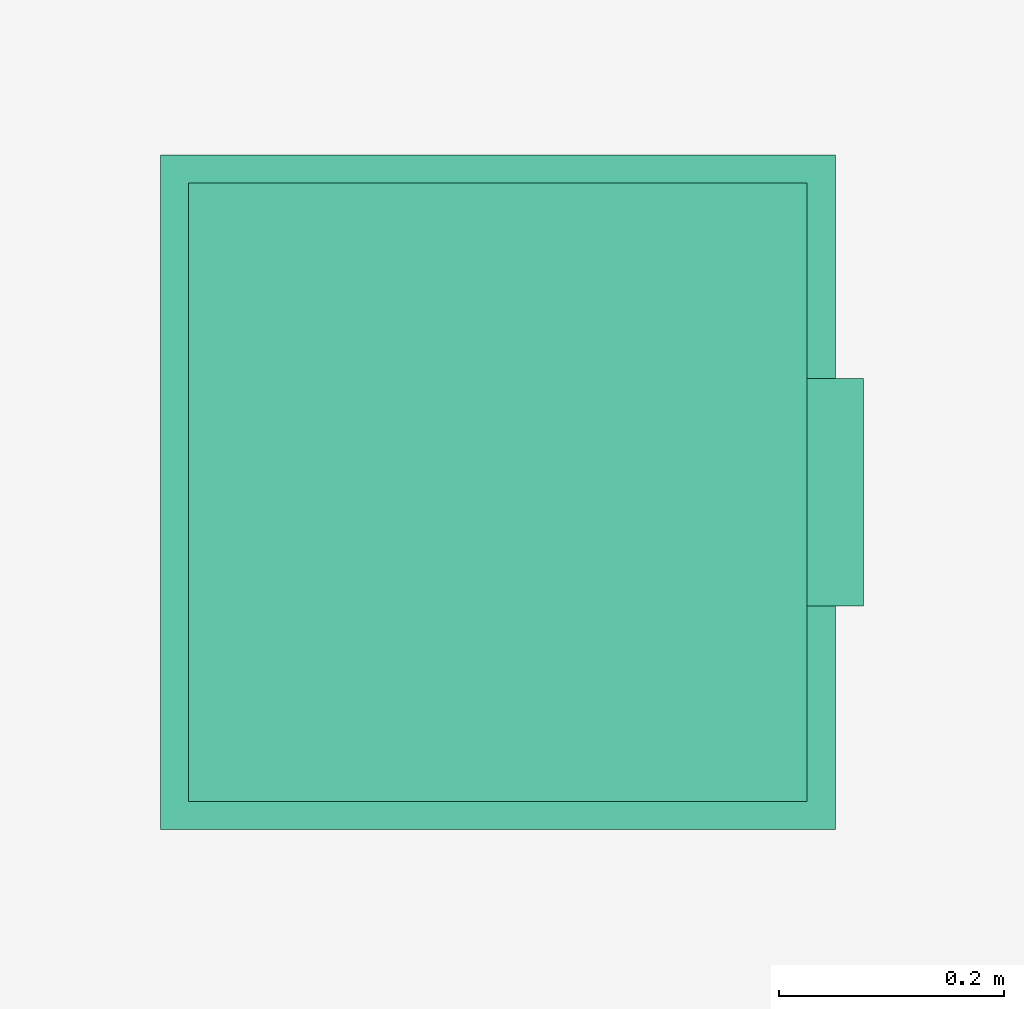
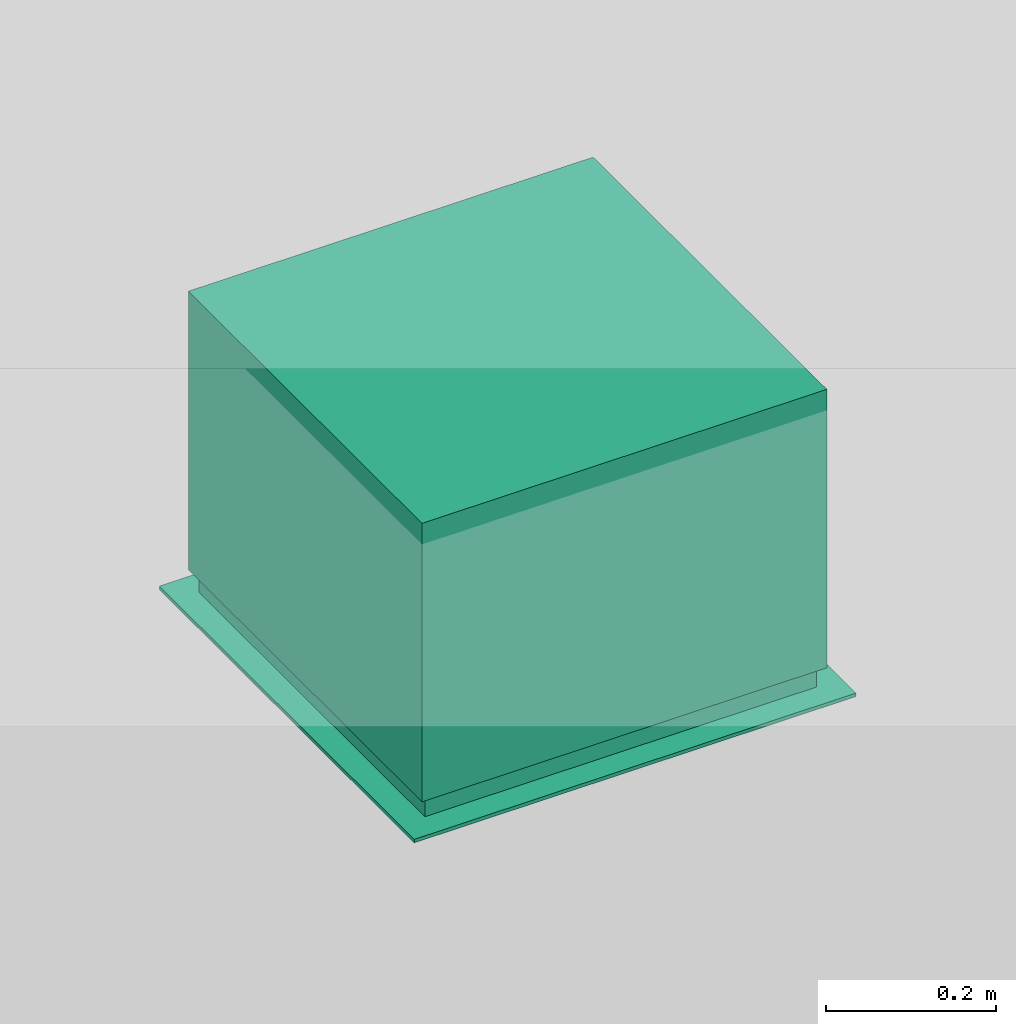
# One storey, part 2 of 2: 1 air terminal.
"""IFC4 building model written with IfcOpenShell, lengths in metres."""

from ifc_helpers import new_model, entity, si_unit, converted_unit, derived_unit, direction, frame, origin_with_axes, place, context, subcontext, project, spatial, open_shell, faceted_brep, surface_model, type_object, element, save


model = new_model("IFC4")

# Units and contexts
model_context = context("Model", 3, precision=1e-05, world=origin_with_axes(), true_north=direction((0.0, 1.0)))
plan_context = context("Plan", 3, precision=1e-05, world=origin_with_axes(), true_north=direction((0.0, 1.0)))
body_context = subcontext(model_context, "Body", "Model", "MODEL_VIEW")
ifc_project = project(units=[si_unit("LENGTHUNIT", "METRE"), si_unit("AREAUNIT", "SQUARE_METRE"), si_unit("VOLUMEUNIT", "CUBIC_METRE"), converted_unit("PLANEANGLEUNIT", "DEGREE", entity("IfcPlaneAngleMeasure", 0.0174532925199), si_unit("PLANEANGLEUNIT", "RADIAN"), dimensions=[0, 0, 0, 0, 0, 0, 0]), si_unit("SOLIDANGLEUNIT", "STERADIAN"), converted_unit("TIMEUNIT", "Year", entity("IfcTimeMeasure", 31556926.0), si_unit("TIMEUNIT", "SECOND"), dimensions=[0, 0, 1, 0, 0, 0, 0]), si_unit("MASSUNIT", "GRAM", prefix="KILO"), si_unit("THERMODYNAMICTEMPERATUREUNIT", "DEGREE_CELSIUS"), si_unit("LUMINOUSINTENSITYUNIT", "LUMEN"), si_unit("ENERGYUNIT", "JOULE", prefix="MEGA"), derived_unit("THERMALCONDUCTANCEUNIT", [(si_unit("POWERUNIT", "WATT"), 1), (si_unit("LENGTHUNIT", "METRE"), -1), (si_unit("THERMODYNAMICTEMPERATUREUNIT", "KELVIN"), -1)]), derived_unit("SPECIFICHEATCAPACITYUNIT", [(si_unit("ENERGYUNIT", "JOULE"), 1), (si_unit("MASSUNIT", "GRAM", prefix="KILO"), -1), (si_unit("THERMODYNAMICTEMPERATUREUNIT", "KELVIN"), -1)]), derived_unit("MASSDENSITYUNIT", [(si_unit("MASSUNIT", "GRAM", prefix="KILO"), 1), (si_unit("VOLUMEUNIT", "CUBIC_METRE"), -1)])], contexts=[model_context, plan_context])

# Site, building, storey, space
site_placement = place(None, origin_with_axes())
site = spatial("IfcSite", under=ifc_project, at=site_placement, CompositionType="ELEMENT")
building_placement = place(site_placement, origin_with_axes())
building = spatial("IfcBuilding", under=site, at=building_placement, Name="Test-Building", CompositionType="ELEMENT")
storey_placement = place(building_placement, origin_with_axes())
storey = spatial("IfcBuildingStorey", under=building, at=storey_placement, Name="EG", CompositionType="ELEMENT", Elevation=0.0)
space_placement = place(storey_placement, frame((0.4, 5.33, 0.0), z_axis=(0.0, 0.0, 1.0), x_axis=(0.0, -1.0, 0.0)))
space = spatial("IfcSpace", under=storey, at=space_placement, CompositionType="ELEMENT")

# Air terminal
air_terminal_type = type_object("IfcAirTerminalType", Name="22", PredefinedType="DIFFUSER")
air_terminal_placement = place(space_placement, frame((1.30756306791, 5.44595197786, 2.6), z_axis=(0.0, 0.0, 1.0), x_axis=(0.0, 1.0, 0.0)))
element("IfcAirTerminal", 1, at=air_terminal_placement, inside=space, type_object=air_terminal_type, Name="Air Terminal", context=body_context, shape_type="SurfaceModel", body=[
    faceted_brep([(-0.3, -0.3, -0.005), (0.3, -0.3, -0.005), (0.3, -0.3, 0.0), (-0.3, -0.3, 0.0), (-0.3, 0.3, -0.005), (0.3, 0.3, -0.005), (0.25, 0.0, -0.005), (0.246201938253, 0.0434120444167, -0.005), (0.234923155196, 0.0855050358314, -0.005), (0.216506350946, 0.125, -0.005), (0.19151111078, 0.160696902422, -0.005), (0.160696902422, 0.19151111078, -0.005), (0.125, 0.216506350946, -0.005), (0.0855050358314, 0.234923155196, -0.005), (0.0434120444167, 0.246201938253, -0.005), (0.0, 0.25, -0.005), (-0.0434120444167, 0.246201938253, -0.005), (-0.0855050358314, 0.234923155196, -0.005), (-0.125, 0.216506350946, -0.005), (-0.160696902422, 0.19151111078, -0.005), (-0.19151111078, 0.160696902422, -0.005), (-0.216506350946, 0.125, -0.005), (-0.234923155196, 0.0855050358314, -0.005), (-0.246201938253, 0.0434120444167, -0.005), (-0.25, 0.0, -0.005), (-0.246201938253, -0.0434120444167, -0.005), (-0.234923155196, -0.0855050358314, -0.005), (-0.216506350946, -0.125, -0.005), (-0.19151111078, -0.160696902422, -0.005), (-0.160696902422, -0.19151111078, -0.005), (-0.125, -0.216506350946, -0.005), (-0.0855050358314, -0.234923155196, -0.005), (-0.0434120444167, -0.246201938253, -0.005), (0.0, -0.25, -0.005), (0.0434120444167, -0.246201938253, -0.005), (0.0855050358314, -0.234923155196, -0.005), (0.125, -0.216506350946, -0.005), (0.160696902422, -0.19151111078, -0.005), (0.19151111078, -0.160696902422, -0.005), (0.216506350946, -0.125, -0.005), (0.234923155196, -0.0855050358314, -0.005), (0.246201938253, -0.0434120444167, -0.005), (0.3, 0.3, 0.0), (-0.3, 0.3, 0.0), (0.25, 0.0, 0.0), (0.246201938253, -0.0434120444167, 0.0), (0.234923155196, -0.0855050358314, 0.0), (0.216506350946, -0.125, 0.0), (0.19151111078, -0.160696902422, 0.0), (0.160696902422, -0.19151111078, 0.0), (0.125, -0.216506350946, 0.0), (0.0855050358314, -0.234923155196, 0.0), (0.0434120444167, -0.246201938253, 0.0), (0.0, -0.25, 0.0), (-0.0434120444167, -0.246201938253, 0.0), (-0.0855050358314, -0.234923155196, 0.0), (-0.125, -0.216506350946, 0.0), (-0.160696902422, -0.19151111078, 0.0), (-0.19151111078, -0.160696902422, 0.0), (-0.216506350946, -0.125, 0.0), (-0.234923155196, -0.0855050358314, 0.0), (-0.246201938253, -0.0434120444167, 0.0), (-0.25, 0.0, 0.0), (-0.246201938253, 0.0434120444167, 0.0), (-0.234923155196, 0.0855050358314, 0.0), (-0.216506350946, 0.125, 0.0), (-0.19151111078, 0.160696902422, 0.0), (-0.160696902422, 0.19151111078, 0.0), (-0.125, 0.216506350946, 0.0), (-0.0855050358314, 0.234923155196, 0.0), (-0.0434120444167, 0.246201938253, 0.0), (0.0, 0.25, 0.0), (0.0434120444167, 0.246201938253, 0.0), (0.0855050358314, 0.234923155196, 0.0), (0.125, 0.216506350946, 0.0), (0.160696902422, 0.19151111078, 0.0), (0.19151111078, 0.160696902422, 0.0), (0.216506350946, 0.125, 0.0), (0.234923155196, 0.0855050358314, 0.0), (0.246201938253, 0.0434120444167, 0.0)], [[[0, 1, 2, 3]], [[0, 4, 5, 1], [6, 7, 8, 9, 10, 11, 12, 13, 14, 15, 16, 17, 18, 19, 20, 21, 22, 23, 24, 25, 26, 27, 28, 29, 30, 31, 32, 33, 34, 35, 36, 37, 38, 39, 40, 41]], [[1, 5, 42, 2]], [[3, 2, 42, 43], [44, 45, 46, 47, 48, 49, 50, 51, 52, 53, 54, 55, 56, 57, 58, 59, 60, 61, 62, 63, 64, 65, 66, 67, 68, 69, 70, 71, 72, 73, 74, 75, 76, 77, 78, 79]], [[4, 0, 3, 43]], [[5, 4, 43, 42]], [[7, 6, 44, 79]], [[8, 7, 79, 78]], [[9, 8, 78, 77]], [[10, 9, 77, 76]], [[11, 10, 76, 75]], [[12, 11, 75, 74]], [[13, 12, 74, 73]], [[14, 13, 73, 72]], [[15, 14, 72, 71]], [[16, 15, 71, 70]], [[17, 16, 70, 69]], [[18, 17, 69, 68]], [[19, 18, 68, 67]], [[20, 19, 67, 66]], [[21, 20, 66, 65]], [[22, 21, 65, 64]], [[23, 22, 64, 63]], [[24, 23, 63, 62]], [[25, 24, 62, 61]], [[26, 25, 61, 60]], [[27, 26, 60, 59]], [[28, 27, 59, 58]], [[29, 28, 58, 57]], [[30, 29, 57, 56]], [[31, 30, 56, 55]], [[32, 31, 55, 54]], [[33, 32, 54, 53]], [[34, 33, 53, 52]], [[35, 34, 52, 51]], [[36, 35, 51, 50]], [[37, 36, 50, 49]], [[38, 37, 49, 48]], [[39, 38, 48, 47]], [[40, 39, 47, 46]], [[41, 40, 46, 45]], [[6, 41, 45, 44]]]),
    surface_model("IfcShellBasedSurfaceModel", [(-0.0434120444167, 0.246201938253, 0.04), (0.0, 0.25, 0.04), (0.0, 0.25, 0.0), (-0.0434120444167, 0.246201938253, 0.0), (0.0434120444167, 0.246201938253, 0.04), (0.0434120444167, 0.246201938253, 0.0), (-0.0855050358314, 0.234923155196, 0.04), (-0.0855050358314, 0.234923155196, 0.0), (0.0855050358314, 0.234923155196, 0.04), (0.0855050358314, 0.234923155196, 0.0), (-0.125, 0.216506350946, 0.04), (-0.125, 0.216506350946, 0.0), (0.125, 0.216506350946, 0.04), (0.125, 0.216506350946, 0.0), (-0.160696902422, 0.19151111078, 0.04), (-0.160696902422, 0.19151111078, 0.0), (0.160696902422, 0.19151111078, 0.04), (0.160696902422, 0.19151111078, 0.0), (-0.19151111078, 0.160696902422, 0.04), (-0.19151111078, 0.160696902422, 0.0), (0.19151111078, 0.160696902422, 0.04), (0.19151111078, 0.160696902422, 0.0), (-0.216506350946, 0.125, 0.04), (-0.216506350946, 0.125, 0.0), (0.216506350946, 0.125, 0.04), (0.216506350946, 0.125, 0.0), (-0.234923155196, 0.0855050358314, 0.04), (-0.234923155196, 0.0855050358314, 0.0), (0.234923155196, 0.0855050358314, 0.04), (0.234923155196, 0.0855050358314, 0.0), (-0.246201938253, 0.0434120444167, 0.04), (-0.246201938253, 0.0434120444167, 0.0), (0.246201938253, 0.0434120444167, 0.04), (0.246201938253, 0.0434120444167, 0.0), (-0.25, 0.0, 0.04), (-0.25, 0.0, 0.0), (0.25, 0.0, 0.04), (0.25, 0.0, 0.0), (-0.246201938253, -0.0434120444167, 0.04), (-0.246201938253, -0.0434120444167, 0.0), (0.246201938253, -0.0434120444167, 0.04), (0.246201938253, -0.0434120444167, 0.0), (-0.234923155196, -0.0855050358314, 0.04), (-0.234923155196, -0.0855050358314, 0.0), (0.234923155196, -0.0855050358314, 0.04), (0.234923155196, -0.0855050358314, 0.0), (-0.216506350946, -0.125, 0.04), (-0.216506350946, -0.125, 0.0), (0.216506350946, -0.125, 0.04), (0.216506350946, -0.125, 0.0), (-0.19151111078, -0.160696902422, 0.04), (-0.19151111078, -0.160696902422, 0.0), (0.19151111078, -0.160696902422, 0.04), (0.19151111078, -0.160696902422, 0.0), (-0.160696902422, -0.19151111078, 0.04), (-0.160696902422, -0.19151111078, 0.0), (0.160696902422, -0.19151111078, 0.04), (0.160696902422, -0.19151111078, 0.0), (-0.125, -0.216506350946, 0.04), (-0.125, -0.216506350946, 0.0), (0.125, -0.216506350946, 0.04), (0.125, -0.216506350946, 0.0), (-0.0855050358314, -0.234923155196, 0.04), (-0.0855050358314, -0.234923155196, 0.0), (0.0855050358314, -0.234923155196, 0.04), (0.0855050358314, -0.234923155196, 0.0), (-0.0434120444167, -0.246201938253, 0.04), (-0.0434120444167, -0.246201938253, 0.0), (0.0434120444167, -0.246201938253, 0.04), (0.0434120444167, -0.246201938253, 0.0), (0.0, -0.25, 0.04), (0.0, -0.25, 0.0)], [open_shell([[[0, 1, 2, 3]], [[1, 4, 5, 2]], [[6, 0, 3, 7]], [[4, 8, 9, 5]], [[10, 6, 7, 11]], [[8, 12, 13, 9]], [[14, 10, 11, 15]], [[12, 16, 17, 13]], [[18, 14, 15, 19]], [[16, 20, 21, 17]], [[22, 18, 19, 23]], [[20, 24, 25, 21]], [[26, 22, 23, 27]], [[24, 28, 29, 25]], [[30, 26, 27, 31]], [[28, 32, 33, 29]], [[34, 30, 31, 35]], [[32, 36, 37, 33]], [[38, 34, 35, 39]], [[36, 40, 41, 37]], [[42, 38, 39, 43]], [[40, 44, 45, 41]], [[46, 42, 43, 47]], [[44, 48, 49, 45]], [[50, 46, 47, 51]], [[48, 52, 53, 49]], [[54, 50, 51, 55]], [[52, 56, 57, 53]], [[58, 54, 55, 59]], [[56, 60, 61, 57]], [[62, 58, 59, 63]], [[60, 64, 65, 61]], [[66, 62, 63, 67]], [[64, 68, 69, 65]], [[70, 66, 67, 71]], [[68, 70, 71, 69]]])]),
    faceted_brep([(0.0833333333333, 0.0, 0.0), (0.082067312751, 0.0144706814722, 0.0), (0.082067312751, 0.0144706814722, 0.04), (0.0833333333333, 0.0, 0.04), (0.082067312751, -0.0144706814722, 0.0), (0.0783077183988, -0.0285016786105, 0.0), (0.0721687836487, -0.0416666666667, 0.0), (0.0638370369266, -0.0535656341405, 0.0), (0.0535656341405, -0.0638370369266, 0.0), (0.0416666666667, -0.0721687836487, 0.0), (0.0285016786105, -0.0783077183988, 0.0), (0.0144706814722, -0.082067312751, 0.0), (0.0, -0.0833333333333, 0.0), (-0.0144706814722, -0.082067312751, 0.0), (-0.0285016786105, -0.0783077183988, 0.0), (-0.0416666666667, -0.0721687836487, 0.0), (-0.0535656341405, -0.0638370369266, 0.0), (-0.0638370369266, -0.0535656341405, 0.0), (-0.0721687836487, -0.0416666666667, 0.0), (-0.0783077183988, -0.0285016786105, 0.0), (-0.082067312751, -0.0144706814722, 0.0), (-0.0833333333333, 0.0, 0.0), (-0.082067312751, 0.0144706814722, 0.0), (-0.0783077183988, 0.0285016786105, 0.0), (-0.0721687836487, 0.0416666666667, 0.0), (-0.0638370369266, 0.0535656341405, 0.0), (-0.0535656341405, 0.0638370369266, 0.0), (-0.0416666666667, 0.0721687836487, 0.0), (-0.0285016786105, 0.0783077183988, 0.0), (-0.0144706814722, 0.082067312751, 0.0), (0.0, 0.0833333333333, 0.0), (0.0144706814722, 0.082067312751, 0.0), (0.0285016786105, 0.0783077183988, 0.0), (0.0416666666667, 0.0721687836487, 0.0), (0.0535656341405, 0.0638370369266, 0.0), (0.0638370369266, 0.0535656341405, 0.0), (0.0721687836487, 0.0416666666667, 0.0), (0.0783077183988, 0.0285016786105, 0.0), (0.0783077183988, 0.0285016786105, 0.04), (0.0721687836487, 0.0416666666667, 0.04), (0.0638370369266, 0.0535656341405, 0.04), (0.0535656341405, 0.0638370369266, 0.04), (0.0416666666667, 0.0721687836487, 0.04), (0.0285016786105, 0.0783077183988, 0.04), (0.0144706814722, 0.082067312751, 0.04), (0.0, 0.0833333333333, 0.04), (-0.0144706814722, 0.082067312751, 0.04), (-0.0285016786105, 0.0783077183988, 0.04), (-0.0416666666667, 0.0721687836487, 0.04), (-0.0535656341405, 0.0638370369266, 0.04), (-0.0638370369266, 0.0535656341405, 0.04), (-0.0721687836487, 0.0416666666667, 0.04), (-0.0783077183988, 0.0285016786105, 0.04), (-0.082067312751, 0.0144706814722, 0.04), (-0.0833333333333, 0.0, 0.04), (-0.082067312751, -0.0144706814722, 0.04), (-0.0783077183988, -0.0285016786105, 0.04), (-0.0721687836487, -0.0416666666667, 0.04), (-0.0638370369266, -0.0535656341405, 0.04), (-0.0535656341405, -0.0638370369266, 0.04), (-0.0416666666667, -0.0721687836487, 0.04), (-0.0285016786105, -0.0783077183988, 0.04), (-0.0144706814722, -0.082067312751, 0.04), (0.0, -0.0833333333333, 0.04), (0.0144706814722, -0.082067312751, 0.04), (0.0285016786105, -0.0783077183988, 0.04), (0.0416666666667, -0.0721687836487, 0.04), (0.0535656341405, -0.0638370369266, 0.04), (0.0638370369266, -0.0535656341405, 0.04), (0.0721687836487, -0.0416666666667, 0.04), (0.0783077183988, -0.0285016786105, 0.04), (0.082067312751, -0.0144706814722, 0.04)], [[[0, 1, 2, 3]], [[0, 4, 5, 6, 7, 8, 9, 10, 11, 12, 13, 14, 15, 16, 17, 18, 19, 20, 21, 22, 23, 24, 25, 26, 27, 28, 29, 30, 31, 32, 33, 34, 35, 36, 37, 1]], [[1, 37, 38, 2]], [[3, 2, 38, 39, 40, 41, 42, 43, 44, 45, 46, 47, 48, 49, 50, 51, 52, 53, 54, 55, 56, 57, 58, 59, 60, 61, 62, 63, 64, 65, 66, 67, 68, 69, 70, 71]], [[4, 0, 3, 71]], [[5, 4, 71, 70]], [[6, 5, 70, 69]], [[7, 6, 69, 68]], [[8, 7, 68, 67]], [[9, 8, 67, 66]], [[10, 9, 66, 65]], [[11, 10, 65, 64]], [[12, 11, 64, 63]], [[13, 12, 63, 62]], [[14, 13, 62, 61]], [[15, 14, 61, 60]], [[16, 15, 60, 59]], [[17, 16, 59, 58]], [[18, 17, 58, 57]], [[19, 18, 57, 56]], [[20, 19, 56, 55]], [[21, 20, 55, 54]], [[22, 21, 54, 53]], [[23, 22, 53, 52]], [[24, 23, 52, 51]], [[25, 24, 51, 50]], [[26, 25, 50, 49]], [[27, 26, 49, 48]], [[28, 27, 48, 47]], [[29, 28, 47, 46]], [[30, 29, 46, 45]], [[31, 30, 45, 44]], [[32, 31, 44, 43]], [[33, 32, 43, 42]], [[34, 33, 42, 41]], [[35, 34, 41, 40]], [[36, 35, 40, 39]], [[37, 36, 39, 38]]]),
    surface_model("IfcShellBasedSurfaceModel", [(0.0875, 0.0, 0.0), (0.0799352275437, 0.0355894562691, 0.0133333333333), (0.223818637122, 0.0996504775536, 0.04), (0.245, 0.0, 0.0)], [open_shell([[[0, 1, 2, 3]]])]),
    surface_model("IfcShellBasedSurfaceModel", [(0.0845185098003, 0.0226466664465, 0.0), (0.0680002716275, 0.0550655342169, 0.0133333333333), (0.190400760557, 0.154183495807, 0.04), (0.236651827441, 0.0634106660501, 0.0)], [open_shell([[[0, 1, 2, 3]]])]),
    surface_model("IfcShellBasedSurfaceModel", [(0.0757772228311, 0.04375, 0.0), (0.0514312095756, 0.0707889870078, 0.0133333333333), (0.144007386812, 0.198209163622, 0.04), (0.212176223927, 0.1225, 0.0)], [open_shell([[[0, 1, 2, 3]]])]),
    surface_model("IfcShellBasedSurfaceModel", [(0.0618718433538, 0.0618718433538, 0.0), (0.0313571955852, 0.0816882873185, 0.0133333333333), (0.0878001476386, 0.228727204492, 0.04), (0.173241161391, 0.173241161391, 0.0)], [open_shell([[[0, 1, 2, 3]]])]),
    surface_model("IfcShellBasedSurfaceModel", [(0.04375, 0.0757772228311, 0.0), (0.00914624053592, 0.0870206658447, 0.0133333333333), (0.0256094735006, 0.243657864365, 0.04), (0.1225, 0.212176223927, 0.0)], [open_shell([[[0, 1, 2, 3]]])]),
    surface_model("IfcShellBasedSurfaceModel", [(0.0226466664465, 0.0845185098003, 0.0), (-0.013688015691, 0.0864227298021, 0.0133333333333), (-0.0383264439349, 0.241983643446, 0.04), (0.0634106660501, 0.236651827441, 0.0)], [open_shell([[[0, 1, 2, 3]]])]),
    surface_model("IfcShellBasedSurfaceModel", [(0.0, 0.0875, 0.0), (-0.0355894562691, 0.0799352275437, 0.0133333333333), (-0.0996504775536, 0.223818637122, 0.04), (0.0, 0.245, 0.0)], [open_shell([[[0, 1, 2, 3]]])]),
    surface_model("IfcShellBasedSurfaceModel", [(-0.0226466664465, 0.0845185098003, 0.0), (-0.0550655342169, 0.0680002716275, 0.0133333333333), (-0.154183495807, 0.190400760557, 0.04), (-0.0634106660501, 0.236651827441, 0.0)], [open_shell([[[0, 1, 2, 3]]])]),
    surface_model("IfcShellBasedSurfaceModel", [(-0.04375, 0.0757772228311, 0.0), (-0.0707889870078, 0.0514312095756, 0.0133333333333), (-0.198209163622, 0.144007386812, 0.04), (-0.1225, 0.212176223927, 0.0)], [open_shell([[[0, 1, 2, 3]]])]),
    surface_model("IfcShellBasedSurfaceModel", [(-0.0618718433538, 0.0618718433538, 0.0), (-0.0816882873185, 0.0313571955852, 0.0133333333333), (-0.228727204492, 0.0878001476386, 0.04), (-0.173241161391, 0.173241161391, 0.0)], [open_shell([[[0, 1, 2, 3]]])]),
    surface_model("IfcShellBasedSurfaceModel", [(-0.0757772228311, 0.04375, 0.0), (-0.0870206658447, 0.00914624053592, 0.0133333333333), (-0.243657864365, 0.0256094735006, 0.04), (-0.212176223927, 0.1225, 0.0)], [open_shell([[[0, 1, 2, 3]]])]),
    surface_model("IfcShellBasedSurfaceModel", [(-0.0845185098003, 0.0226466664465, 0.0), (-0.0864227298021, -0.013688015691, 0.0133333333333), (-0.241983643446, -0.0383264439349, 0.04), (-0.236651827441, 0.0634106660501, 0.0)], [open_shell([[[0, 1, 2, 3]]])]),
    surface_model("IfcShellBasedSurfaceModel", [(-0.0875, 0.0, 0.0), (-0.0799352275437, -0.0355894562691, 0.0133333333333), (-0.223818637122, -0.0996504775536, 0.04), (-0.245, 0.0, 0.0)], [open_shell([[[0, 1, 2, 3]]])]),
    surface_model("IfcShellBasedSurfaceModel", [(-0.0845185098003, -0.0226466664465, 0.0), (-0.0680002716275, -0.0550655342169, 0.0133333333333), (-0.190400760557, -0.154183495807, 0.04), (-0.236651827441, -0.0634106660501, 0.0)], [open_shell([[[0, 1, 2, 3]]])]),
    surface_model("IfcShellBasedSurfaceModel", [(-0.0757772228311, -0.04375, 0.0), (-0.0514312095756, -0.0707889870078, 0.0133333333333), (-0.144007386812, -0.198209163622, 0.04), (-0.212176223927, -0.1225, 0.0)], [open_shell([[[0, 1, 2, 3]]])]),
    surface_model("IfcShellBasedSurfaceModel", [(-0.0618718433538, -0.0618718433538, 0.0), (-0.0313571955852, -0.0816882873185, 0.0133333333333), (-0.0878001476386, -0.228727204492, 0.04), (-0.173241161391, -0.173241161391, 0.0)], [open_shell([[[0, 1, 2, 3]]])]),
    surface_model("IfcShellBasedSurfaceModel", [(-0.04375, -0.0757772228311, 0.0), (-0.00914624053592, -0.0870206658447, 0.0133333333333), (-0.0256094735006, -0.243657864365, 0.04), (-0.1225, -0.212176223927, 0.0)], [open_shell([[[0, 1, 2, 3]]])]),
    surface_model("IfcShellBasedSurfaceModel", [(-0.0226466664465, -0.0845185098003, 0.0), (0.013688015691, -0.0864227298021, 0.0133333333333), (0.0383264439349, -0.241983643446, 0.04), (-0.0634106660501, -0.236651827441, 0.0)], [open_shell([[[0, 1, 2, 3]]])]),
    surface_model("IfcShellBasedSurfaceModel", [(0.0, -0.0875, 0.0), (0.0355894562691, -0.0799352275437, 0.0133333333333), (0.0996504775536, -0.223818637122, 0.04), (0.0, -0.245, 0.0)], [open_shell([[[0, 1, 2, 3]]])]),
    surface_model("IfcShellBasedSurfaceModel", [(0.0226466664465, -0.0845185098003, 0.0), (0.0550655342169, -0.0680002716275, 0.0133333333333), (0.154183495807, -0.190400760557, 0.04), (0.0634106660501, -0.236651827441, 0.0)], [open_shell([[[0, 1, 2, 3]]])]),
    surface_model("IfcShellBasedSurfaceModel", [(0.04375, -0.0757772228311, 0.0), (0.0707889870078, -0.0514312095756, 0.0133333333333), (0.198209163622, -0.144007386812, 0.04), (0.1225, -0.212176223927, 0.0)], [open_shell([[[0, 1, 2, 3]]])]),
    surface_model("IfcShellBasedSurfaceModel", [(0.0618718433538, -0.0618718433538, 0.0), (0.0816882873185, -0.0313571955852, 0.0133333333333), (0.228727204492, -0.0878001476386, 0.04), (0.173241161391, -0.173241161391, 0.0)], [open_shell([[[0, 1, 2, 3]]])]),
    surface_model("IfcShellBasedSurfaceModel", [(0.0757772228311, -0.04375, 0.0), (0.0870206658447, -0.00914624053592, 0.0133333333333), (0.243657864365, -0.0256094735006, 0.04), (0.212176223927, -0.1225, 0.0)], [open_shell([[[0, 1, 2, 3]]])]),
    surface_model("IfcShellBasedSurfaceModel", [(0.0845185098003, -0.0226466664465, 0.0), (0.0864227298021, 0.013688015691, 0.0133333333333), (0.241983643446, 0.0383264439349, 0.04), (0.236651827441, -0.0634106660501, 0.0)], [open_shell([[[0, 1, 2, 3]]])]),
    surface_model("IfcShellBasedSurfaceModel", [(-0.266, -0.266, 0.0), (0.266, -0.266, 0.0), (0.266, -0.266, 0.03), (-0.266, -0.266, 0.03), (0.266, 0.266, 0.0), (0.266, 0.266, 0.03), (-0.266, 0.266, 0.0), (-0.266, 0.266, 0.03)], [open_shell([[[0, 1, 2, 3]], [[1, 4, 5, 2]], [[6, 0, 3, 7]], [[4, 6, 7, 5]]])]),
    surface_model("IfcShellBasedSurfaceModel", [(-0.275, -0.275, 0.03), (-0.275, 0.275, 0.03), (0.275, 0.275, 0.03), (0.275, -0.275, 0.03), (-0.266, -0.266, 0.03), (0.266, -0.266, 0.03), (0.266, 0.266, 0.03), (-0.266, 0.266, 0.03)], [open_shell([[[0, 1, 2, 3], [4, 5, 6, 7]]])]),
    surface_model("IfcShellBasedSurfaceModel", [(0.275, 0.275, 0.43), (0.275, -0.275, 0.43), (0.275, -0.275, 0.03), (0.275, 0.275, 0.03), (0.275, 0.0874685657822, 0.2755), (0.275, 0.0975585084552, 0.251140723555), (0.275, 0.101, 0.225), (0.275, 0.0975585084552, 0.198859276445), (0.275, 0.0874685657822, 0.1745), (0.275, 0.0714177848998, 0.1535822151), (0.275, 0.0505, 0.137531434218), (0.275, 0.0261407235554, 0.127441491545), (0.275, 0.0, 0.124), (0.275, -0.0261407235554, 0.127441491545), (0.275, -0.0505, 0.137531434218), (0.275, -0.0714177848998, 0.1535822151), (0.275, -0.0874685657822, 0.1745), (0.275, -0.0975585084552, 0.198859276445), (0.275, -0.101, 0.225), (0.275, -0.0975585084552, 0.251140723555), (0.275, -0.0874685657822, 0.2755), (0.275, -0.0714177848998, 0.2964177849), (0.275, -0.0505, 0.312468565782), (0.275, -0.0261407235554, 0.322558508455), (0.275, 0.0, 0.326), (0.275, 0.0261407235554, 0.322558508455), (0.275, 0.0505, 0.312468565782), (0.275, 0.0714177848998, 0.2964177849), (-0.275, 0.275, 0.43), (-0.275, -0.275, 0.43), (-0.275, -0.275, 0.03), (-0.275, 0.275, 0.03)], [open_shell([[[0, 1, 2, 3], [4, 5, 6, 7, 8, 9, 10, 11, 12, 13, 14, 15, 16, 17, 18, 19, 20, 21, 22, 23, 24, 25, 26, 27]], [[1, 0, 28, 29]], [[2, 1, 29, 30]], [[31, 28, 0, 3]], [[30, 29, 28, 31]]])]),
    surface_model("IfcShellBasedSurfaceModel", [(0.275, 0.0, 0.124), (0.275, 0.0261407235554, 0.127441491545), (0.325, 0.0261407235554, 0.127441491545), (0.325, 0.0, 0.124), (0.275, 0.0505, 0.137531434218), (0.325, 0.0505, 0.137531434218), (0.275, -0.0261407235554, 0.127441491545), (0.325, -0.0261407235554, 0.127441491545), (0.275, 0.0714177848998, 0.1535822151), (0.325, 0.0714177848998, 0.1535822151), (0.275, -0.0505, 0.137531434218), (0.325, -0.0505, 0.137531434218), (0.275, 0.0874685657822, 0.1745), (0.325, 0.0874685657822, 0.1745), (0.275, -0.0714177848998, 0.1535822151), (0.325, -0.0714177848998, 0.1535822151), (0.275, 0.0975585084552, 0.198859276445), (0.325, 0.0975585084552, 0.198859276445), (0.275, -0.0874685657822, 0.1745), (0.325, -0.0874685657822, 0.1745), (0.275, 0.101, 0.225), (0.325, 0.101, 0.225), (0.275, -0.0975585084552, 0.198859276445), (0.325, -0.0975585084552, 0.198859276445), (0.275, 0.0975585084552, 0.251140723555), (0.325, 0.0975585084552, 0.251140723555), (0.275, -0.101, 0.225), (0.325, -0.101, 0.225), (0.275, 0.0874685657822, 0.2755), (0.325, 0.0874685657822, 0.2755), (0.275, -0.0975585084552, 0.251140723555), (0.325, -0.0975585084552, 0.251140723555), (0.275, 0.0714177848998, 0.2964177849), (0.325, 0.0714177848998, 0.2964177849), (0.275, -0.0874685657822, 0.2755), (0.325, -0.0874685657822, 0.2755), (0.275, 0.0505, 0.312468565782), (0.325, 0.0505, 0.312468565782), (0.275, -0.0714177848998, 0.2964177849), (0.325, -0.0714177848998, 0.2964177849), (0.275, 0.0261407235554, 0.322558508455), (0.325, 0.0261407235554, 0.322558508455), (0.275, -0.0505, 0.312468565782), (0.325, -0.0505, 0.312468565782), (0.275, 0.0, 0.326), (0.325, 0.0, 0.326), (0.275, -0.0261407235554, 0.322558508455), (0.325, -0.0261407235554, 0.322558508455)], [open_shell([[[0, 1, 2, 3]], [[1, 4, 5, 2]], [[6, 0, 3, 7]], [[4, 8, 9, 5]], [[10, 6, 7, 11]], [[8, 12, 13, 9]], [[14, 10, 11, 15]], [[12, 16, 17, 13]], [[18, 14, 15, 19]], [[16, 20, 21, 17]], [[22, 18, 19, 23]], [[20, 24, 25, 21]], [[26, 22, 23, 27]], [[24, 28, 29, 25]], [[30, 26, 27, 31]], [[28, 32, 33, 29]], [[34, 30, 31, 35]], [[32, 36, 37, 33]], [[38, 34, 35, 39]], [[36, 40, 41, 37]], [[42, 38, 39, 43]], [[40, 44, 45, 41]], [[46, 42, 43, 47]], [[44, 46, 47, 45]]])]),
])

save(model, "model.ifc")
